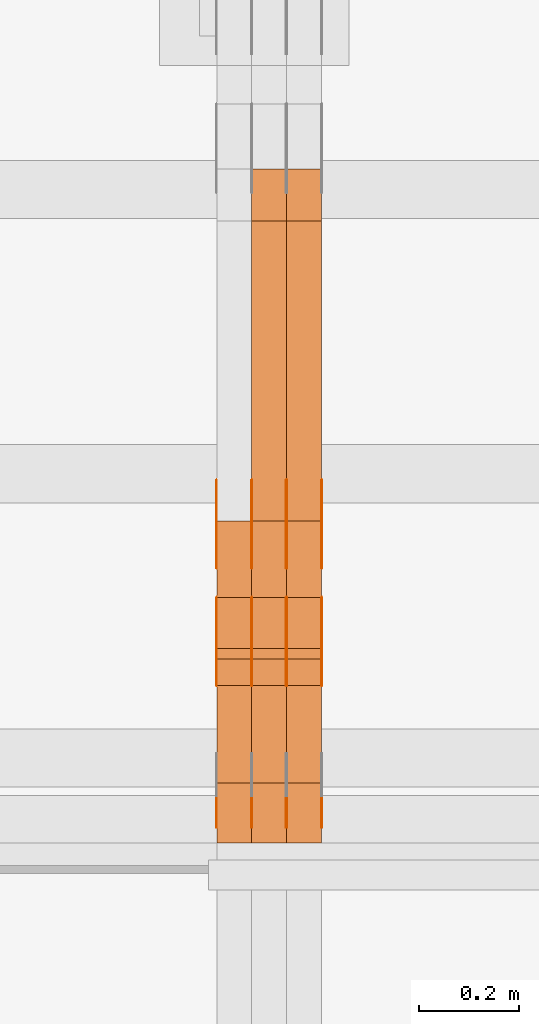
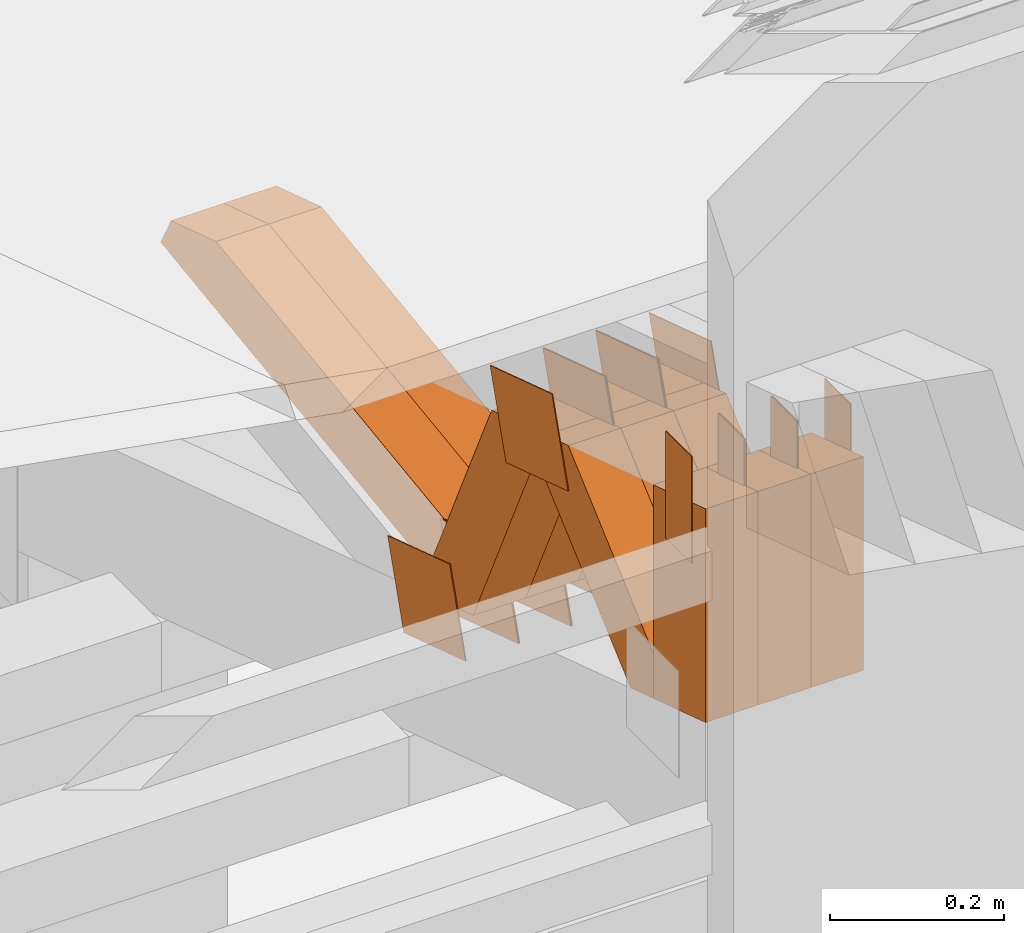
# One storey, part 286 of 385: 29 proxies.
"""IFC2X3 building model written with IfcOpenShell, lengths in millimetres."""

from ifc_helpers import new_model, entity, si_unit, converted_unit, derived_unit, direction, frame, origin, origin_2d_with_axis, place, context, subcontext, project, spatial, polyline, rectangle, outline, extrude, source, transform, mapped, material, type_object, type_shapes, element, save


model = new_model("IFC2X3")

# Units and contexts
model_context = context("Model", 3, precision=0.01, world=origin(), true_north=direction((6.12303176911189e-17, 1.0)))
body_context = subcontext(model_context, "Body", "Model", "MODEL_VIEW")
ifc_project = project(units=[si_unit("LENGTHUNIT", "METRE", prefix="MILLI"), si_unit("AREAUNIT", "SQUARE_METRE"), si_unit("VOLUMEUNIT", "CUBIC_METRE"), converted_unit("PLANEANGLEUNIT", "DEGREE", entity("IfcRatioMeasure", 0.0174532925199433), si_unit("PLANEANGLEUNIT", "RADIAN"), dimensions=[0, 0, 0, 0, 0, 0, 0]), si_unit("MASSUNIT", "GRAM", prefix="KILO"), derived_unit("MASSDENSITYUNIT", [(si_unit("MASSUNIT", "GRAM", prefix="KILO"), 1), (si_unit("LENGTHUNIT", "METRE"), -3)]), si_unit("TIMEUNIT", "SECOND"), si_unit("FREQUENCYUNIT", "HERTZ"), si_unit("THERMODYNAMICTEMPERATUREUNIT", "DEGREE_CELSIUS"), derived_unit("THERMALTRANSMITTANCEUNIT", [(si_unit("MASSUNIT", "GRAM", prefix="KILO"), 1), (si_unit("THERMODYNAMICTEMPERATUREUNIT", "KELVIN"), -1), (si_unit("TIMEUNIT", "SECOND"), -3)]), derived_unit("VOLUMETRICFLOWRATEUNIT", [(si_unit("LENGTHUNIT", "METRE"), 3), (si_unit("TIMEUNIT", "SECOND"), -1)]), si_unit("ELECTRICCURRENTUNIT", "AMPERE"), si_unit("ELECTRICVOLTAGEUNIT", "VOLT"), si_unit("POWERUNIT", "WATT"), si_unit("FORCEUNIT", "NEWTON", prefix="KILO"), si_unit("ILLUMINANCEUNIT", "LUX"), si_unit("LUMINOUSFLUXUNIT", "LUMEN"), si_unit("LUMINOUSINTENSITYUNIT", "CANDELA"), derived_unit("USERDEFINED", [(si_unit("MASSUNIT", "GRAM", prefix="KILO"), -1), (si_unit("LENGTHUNIT", "METRE"), -2), (si_unit("TIMEUNIT", "SECOND"), 3), (si_unit("LUMINOUSFLUXUNIT", "LUMEN"), 1)]), derived_unit("LINEARVELOCITYUNIT", [(si_unit("LENGTHUNIT", "METRE"), 1), (si_unit("TIMEUNIT", "SECOND"), -1)]), si_unit("PRESSUREUNIT", "PASCAL"), derived_unit("USERDEFINED", [(si_unit("LENGTHUNIT", "METRE"), -2), (si_unit("MASSUNIT", "GRAM", prefix="KILO"), 1), (si_unit("TIMEUNIT", "SECOND"), -2)])], contexts=[model_context])

# Site, building, storey
site_placement = place(None, origin())
site = spatial("IfcSite", under=ifc_project, at=site_placement, CompositionType="ELEMENT")
building_placement = place(site_placement, origin())
building = spatial("IfcBuilding", under=site, at=building_placement, CompositionType="ELEMENT")
storey_placement = place(building_placement, origin())
storey = spatial("IfcBuildingStorey", under=building, at=storey_placement, Name="Default", CompositionType="ELEMENT", Elevation=0.0)

# Proxies
ifc_material_1 = material(Name="IfcSurfaceStyle #411628")
building_element_proxy_type_1 = type_object("IfcBuildingElementProxyType", PredefinedType="NOTDEFINED", material=ifc_material_1)
shared_shape_1 = source(origin(), body_context, "Body", "SweptSolid", [
    extrude(outline(polyline([(-74.9998605591118, -59.9999264677601), (74.9998754286171, -59.9999264677601), (74.9998605591118, 59.9999264677602), (-74.9998754286171, 59.9999264677602), (-74.9998605591118, -59.9999264677601)])), frame((74.9998754286171, 60.0000503992849, 0.0), z_axis=(0.0, 0.0, 1.0), x_axis=(-1.0, 0.0, 0.0)), (0.0, 0.0, 1.0), 1.3),
])
type_shapes(building_element_proxy_type_1, [shared_shape_1])
proxy_1_placement = place(building_placement, frame((33386.3, 16352.8320303235, 3323.23212676408), z_axis=(-1.0, 0.0, 0.0), x_axis=(0.0, -0.951056516295124, 0.309016994375039)))
element("IfcBuildingElementProxy", 1, at=proxy_1_placement, inside=storey, type_object=building_element_proxy_type_1, material=ifc_material_1, context=body_context, shape_type="MappedRepresentation", body=[
    mapped(shared_shape_1, transform((0.0, 0.0, 0.0), scale=1.0)),
])
ifc_material_2 = material(Name="IfcSurfaceStyle #411571")
building_element_proxy_type_2 = type_object("IfcBuildingElementProxyType", PredefinedType="NOTDEFINED", material=ifc_material_2)
shared_shape_2 = source(origin(), body_context, "Body", "SweptSolid", [
    extrude(outline(polyline([(-74.9998605591118, -59.9999264677601), (74.9998754286171, -59.9999264677601), (74.9998605591118, 59.9999264677602), (-74.9998754286171, 59.9999264677602), (-74.9998605591118, -59.9999264677601)])), frame((74.9998754286171, 60.0000503992849, 0.0), z_axis=(0.0, 0.0, 1.0), x_axis=(-1.0, 0.0, 0.0)), (0.0, 0.0, 1.0), 1.3),
])
type_shapes(building_element_proxy_type_2, [shared_shape_2])
proxy_2_placement = place(building_placement, frame((33315.0, 16352.8320303235, 3323.23212676408), z_axis=(-1.0, 0.0, 0.0), x_axis=(0.0, -0.951056516295124, 0.309016994375039)))
element("IfcBuildingElementProxy", 2, at=proxy_2_placement, inside=storey, type_object=building_element_proxy_type_2, material=ifc_material_2, context=body_context, shape_type="MappedRepresentation", body=[
    mapped(shared_shape_2, transform((0.0, 0.0, 0.0), scale=1.0)),
])
ifc_material_3 = material(Name="IfcSurfaceStyle #411514")
building_element_proxy_type_3 = type_object("IfcBuildingElementProxyType", PredefinedType="NOTDEFINED", material=ifc_material_3)
shared_shape_3 = source(origin(), body_context, "Body", "SweptSolid", [
    extrude(outline(polyline([(-74.9998605591118, -59.9999264677601), (74.9998754286171, -59.9999264677601), (74.9998605591118, 59.9999264677602), (-74.9998754286171, 59.9999264677602), (-74.9998605591118, -59.9999264677601)])), frame((74.9998754286171, 60.0000503992849, 0.0), z_axis=(0.0, 0.0, 1.0), x_axis=(-1.0, 0.0, 0.0)), (0.0, 0.0, 1.0), 1.3),
])
type_shapes(building_element_proxy_type_3, [shared_shape_3])
proxy_3_placement = place(building_placement, frame((33316.3, 16352.8320303235, 3323.23212676408), z_axis=(-1.0, 0.0, 0.0), x_axis=(0.0, -0.951056516295124, 0.309016994375039)))
element("IfcBuildingElementProxy", 3, at=proxy_3_placement, inside=storey, type_object=building_element_proxy_type_3, material=ifc_material_3, context=body_context, shape_type="MappedRepresentation", body=[
    mapped(shared_shape_3, transform((0.0, 0.0, 0.0), scale=1.0)),
])
ifc_material_4 = material(Name="IfcSurfaceStyle #411457")
building_element_proxy_type_4 = type_object("IfcBuildingElementProxyType", PredefinedType="NOTDEFINED", material=ifc_material_4)
shared_shape_4 = source(origin(), body_context, "Body", "SweptSolid", [
    extrude(outline(polyline([(-74.9998605591118, -59.9999264677601), (74.9998754286171, -59.9999264677601), (74.9998605591118, 59.9999264677602), (-74.9998754286171, 59.9999264677602), (-74.9998605591118, -59.9999264677601)])), frame((74.9998754286171, 60.0000503992849, 0.0), z_axis=(0.0, 0.0, 1.0), x_axis=(-1.0, 0.0, 0.0)), (0.0, 0.0, 1.0), 1.29999999999999),
])
type_shapes(building_element_proxy_type_4, [shared_shape_4])
proxy_4_placement = place(building_placement, frame((33245.0, 16352.8320303235, 3323.23212676408), z_axis=(-1.0, 0.0, 0.0), x_axis=(0.0, -0.951056516295124, 0.309016994375039)))
element("IfcBuildingElementProxy", 4, at=proxy_4_placement, inside=storey, type_object=building_element_proxy_type_4, material=ifc_material_4, context=body_context, shape_type="MappedRepresentation", body=[
    mapped(shared_shape_4, transform((0.0, 0.0, 0.0), scale=1.0)),
])
ifc_material_5 = material(Name="IfcSurfaceStyle #411400")
building_element_proxy_type_5 = type_object("IfcBuildingElementProxyType", PredefinedType="NOTDEFINED", material=ifc_material_5)
shared_shape_5 = source(origin(), body_context, "Body", "SweptSolid", [
    extrude(outline(polyline([(-74.9998605591118, -59.9999264677601), (74.9998754286171, -59.9999264677601), (74.9998605591118, 59.9999264677602), (-74.9998754286171, 59.9999264677602), (-74.9998605591118, -59.9999264677601)])), frame((74.9998754286171, 60.0000503992849, 0.0), z_axis=(0.0, 0.0, 1.0), x_axis=(-1.0, 0.0, 0.0)), (0.0, 0.0, 1.0), 1.29999999999999),
])
type_shapes(building_element_proxy_type_5, [shared_shape_5])
proxy_5_placement = place(building_placement, frame((33246.3, 16352.8320303235, 3323.23212676408), z_axis=(-1.0, 0.0, 0.0), x_axis=(0.0, -0.951056516295124, 0.309016994375039)))
element("IfcBuildingElementProxy", 5, at=proxy_5_placement, inside=storey, type_object=building_element_proxy_type_5, material=ifc_material_5, context=body_context, shape_type="MappedRepresentation", body=[
    mapped(shared_shape_5, transform((0.0, 0.0, 0.0), scale=1.0)),
])
ifc_material_6 = material(Name="IfcSurfaceStyle #411343")
building_element_proxy_type_6 = type_object("IfcBuildingElementProxyType", PredefinedType="NOTDEFINED", material=ifc_material_6)
shared_shape_6 = source(origin(), body_context, "Body", "SweptSolid", [
    extrude(outline(polyline([(-74.9998605591118, -59.9999264677601), (74.9998754286171, -59.9999264677601), (74.9998605591118, 59.9999264677602), (-74.9998754286171, 59.9999264677602), (-74.9998605591118, -59.9999264677601)])), frame((74.9998754286171, 60.0000503992849, 0.0), z_axis=(0.0, 0.0, 1.0), x_axis=(-1.0, 0.0, 0.0)), (0.0, 0.0, 1.0), 1.29999999999999),
])
type_shapes(building_element_proxy_type_6, [shared_shape_6])
proxy_6_placement = place(building_placement, frame((33175.0, 16352.8320303235, 3323.23212676408), z_axis=(-1.0, 0.0, 0.0), x_axis=(0.0, -0.951056516295124, 0.309016994375039)))
element("IfcBuildingElementProxy", 6, at=proxy_6_placement, inside=storey, type_object=building_element_proxy_type_6, material=ifc_material_6, context=body_context, shape_type="MappedRepresentation", body=[
    mapped(shared_shape_6, transform((0.0, 0.0, 0.0), scale=1.0)),
])
ifc_material_7 = material(Name="IfcSurfaceStyle #407182")
building_element_proxy_type_7 = type_object("IfcBuildingElementProxyType", PredefinedType="NOTDEFINED", material=ifc_material_7)
shared_shape_7 = source(origin(), body_context, "Body", "SweptSolid", [
    extrude(outline(polyline([(-75.0003249421702, -60.0000773549573), (75.0003398116874, -60.0000773549573), (75.0003249421711, 60.0000773549573), (-75.0003398116883, 60.0000773549573), (-75.0003249421702, -60.0000773549573)])), frame((75.0003398116874, 60.0000773549573, 0.0), z_axis=(0.0, 0.0, 1.0), x_axis=(-1.0, 0.0, 0.0)), (0.0, 0.0, 1.0), 1.3),
])
type_shapes(building_element_proxy_type_7, [shared_shape_7])
proxy_7_placement = place(building_placement, frame((33386.3, 16117.0849050545, 3705.49074668796), z_axis=(-1.0, 0.0, 0.0), x_axis=(0.0, -0.951056516295154, 0.309016994374948)))
element("IfcBuildingElementProxy", 7, at=proxy_7_placement, inside=storey, type_object=building_element_proxy_type_7, material=ifc_material_7, context=body_context, shape_type="MappedRepresentation", body=[
    mapped(shared_shape_7, transform((0.0, 0.0, 0.0), scale=1.0)),
])
ifc_material_8 = material(Name="IfcSurfaceStyle #407125")
building_element_proxy_type_8 = type_object("IfcBuildingElementProxyType", PredefinedType="NOTDEFINED", material=ifc_material_8)
shared_shape_8 = source(origin(), body_context, "Body", "SweptSolid", [
    extrude(outline(polyline([(-75.0003249421702, -60.0000773549573), (75.0003398116874, -60.0000773549573), (75.0003249421711, 60.0000773549573), (-75.0003398116883, 60.0000773549573), (-75.0003249421702, -60.0000773549573)])), frame((75.0003398116874, 60.0000773549573, 0.0), z_axis=(0.0, 0.0, 1.0), x_axis=(-1.0, 0.0, 0.0)), (0.0, 0.0, 1.0), 1.3),
])
type_shapes(building_element_proxy_type_8, [shared_shape_8])
proxy_8_placement = place(building_placement, frame((33315.0, 16117.0849050545, 3705.49074668796), z_axis=(-1.0, 0.0, 0.0), x_axis=(0.0, -0.951056516295154, 0.309016994374948)))
element("IfcBuildingElementProxy", 8, at=proxy_8_placement, inside=storey, type_object=building_element_proxy_type_8, material=ifc_material_8, context=body_context, shape_type="MappedRepresentation", body=[
    mapped(shared_shape_8, transform((0.0, 0.0, 0.0), scale=1.0)),
])
ifc_material_9 = material(Name="IfcSurfaceStyle #407068")
building_element_proxy_type_9 = type_object("IfcBuildingElementProxyType", PredefinedType="NOTDEFINED", material=ifc_material_9)
shared_shape_9 = source(origin(), body_context, "Body", "SweptSolid", [
    extrude(outline(polyline([(-75.0003249421702, -60.0000773549573), (75.0003398116874, -60.0000773549573), (75.0003249421711, 60.0000773549573), (-75.0003398116883, 60.0000773549573), (-75.0003249421702, -60.0000773549573)])), frame((75.0003398116874, 60.0000773549573, 0.0), z_axis=(0.0, 0.0, 1.0), x_axis=(-1.0, 0.0, 0.0)), (0.0, 0.0, 1.0), 1.3),
])
type_shapes(building_element_proxy_type_9, [shared_shape_9])
proxy_9_placement = place(building_placement, frame((33316.3, 16117.0849050545, 3705.49074668796), z_axis=(-1.0, 0.0, 0.0), x_axis=(0.0, -0.951056516295154, 0.309016994374948)))
element("IfcBuildingElementProxy", 9, at=proxy_9_placement, inside=storey, type_object=building_element_proxy_type_9, material=ifc_material_9, context=body_context, shape_type="MappedRepresentation", body=[
    mapped(shared_shape_9, transform((0.0, 0.0, 0.0), scale=1.0)),
])
ifc_material_10 = material(Name="IfcSurfaceStyle #407011")
building_element_proxy_type_10 = type_object("IfcBuildingElementProxyType", PredefinedType="NOTDEFINED", material=ifc_material_10)
shared_shape_10 = source(origin(), body_context, "Body", "SweptSolid", [
    extrude(outline(polyline([(-75.0003249421702, -60.0000773549573), (75.0003398116874, -60.0000773549573), (75.0003249421711, 60.0000773549573), (-75.0003398116883, 60.0000773549573), (-75.0003249421702, -60.0000773549573)])), frame((75.0003398116874, 60.0000773549573, 0.0), z_axis=(0.0, 0.0, 1.0), x_axis=(-1.0, 0.0, 0.0)), (0.0, 0.0, 1.0), 1.29999999999999),
])
type_shapes(building_element_proxy_type_10, [shared_shape_10])
proxy_10_placement = place(building_placement, frame((33245.0, 16117.0849050545, 3705.49074668796), z_axis=(-1.0, 0.0, 0.0), x_axis=(0.0, -0.951056516295154, 0.309016994374948)))
element("IfcBuildingElementProxy", 10, at=proxy_10_placement, inside=storey, type_object=building_element_proxy_type_10, material=ifc_material_10, context=body_context, shape_type="MappedRepresentation", body=[
    mapped(shared_shape_10, transform((0.0, 0.0, 0.0), scale=1.0)),
])
ifc_material_11 = material(Name="IfcSurfaceStyle #406954")
building_element_proxy_type_11 = type_object("IfcBuildingElementProxyType", PredefinedType="NOTDEFINED", material=ifc_material_11)
shared_shape_11 = source(origin(), body_context, "Body", "SweptSolid", [
    extrude(outline(polyline([(-75.0003249421702, -60.0000773549573), (75.0003398116874, -60.0000773549573), (75.0003249421711, 60.0000773549573), (-75.0003398116883, 60.0000773549573), (-75.0003249421702, -60.0000773549573)])), frame((75.0003398116874, 60.0000773549573, 0.0), z_axis=(0.0, 0.0, 1.0), x_axis=(-1.0, 0.0, 0.0)), (0.0, 0.0, 1.0), 1.29999999999999),
])
type_shapes(building_element_proxy_type_11, [shared_shape_11])
proxy_11_placement = place(building_placement, frame((33246.3, 16117.0849050545, 3705.49074668796), z_axis=(-1.0, 0.0, 0.0), x_axis=(0.0, -0.951056516295154, 0.309016994374948)))
element("IfcBuildingElementProxy", 11, at=proxy_11_placement, inside=storey, type_object=building_element_proxy_type_11, material=ifc_material_11, context=body_context, shape_type="MappedRepresentation", body=[
    mapped(shared_shape_11, transform((0.0, 0.0, 0.0), scale=1.0)),
])
ifc_material_12 = material(Name="IfcSurfaceStyle #406897")
building_element_proxy_type_12 = type_object("IfcBuildingElementProxyType", PredefinedType="NOTDEFINED", material=ifc_material_12)
shared_shape_12 = source(origin(), body_context, "Body", "SweptSolid", [
    extrude(outline(polyline([(-75.0003249421702, -60.0000773549573), (75.0003398116874, -60.0000773549573), (75.0003249421711, 60.0000773549573), (-75.0003398116883, 60.0000773549573), (-75.0003249421702, -60.0000773549573)])), frame((75.0003398116874, 60.0000773549573, 0.0), z_axis=(0.0, 0.0, 1.0), x_axis=(-1.0, 0.0, 0.0)), (0.0, 0.0, 1.0), 1.29999999999999),
])
type_shapes(building_element_proxy_type_12, [shared_shape_12])
proxy_12_placement = place(building_placement, frame((33175.0, 16117.0849050545, 3705.49074668796), z_axis=(-1.0, 0.0, 0.0), x_axis=(0.0, -0.951056516295154, 0.309016994374948)))
element("IfcBuildingElementProxy", 12, at=proxy_12_placement, inside=storey, type_object=building_element_proxy_type_12, material=ifc_material_12, context=body_context, shape_type="MappedRepresentation", body=[
    mapped(shared_shape_12, transform((0.0, 0.0, 0.0), scale=1.0)),
])
ifc_material_13 = material(Name="IfcSurfaceStyle #406498")
building_element_proxy_type_13 = type_object("IfcBuildingElementProxyType", PredefinedType="NOTDEFINED", material=ifc_material_13)
shared_shape_13 = source(origin(), body_context, "Body", "SweptSolid", [
    extrude(rectangle(XDim=150.0, YDim=60.0, at=origin_2d_with_axis()), frame((75.0000705696311, 30.0, 0.0), z_axis=(0.0, 0.0, 1.0), x_axis=(-1.0, 0.0, 0.0)), (0.0, 0.0, 1.0), 1.3),
])
type_shapes(building_element_proxy_type_13, [shared_shape_13])
proxy_13_placement = place(building_placement, frame((33386.3, 15750.0, 3972.59919166338), z_axis=(-1.0, 0.0, 0.0), x_axis=(0.0, 0.0, -1.0)))
element("IfcBuildingElementProxy", 13, at=proxy_13_placement, inside=storey, type_object=building_element_proxy_type_13, material=ifc_material_13, context=body_context, shape_type="MappedRepresentation", body=[
    mapped(shared_shape_13, transform((0.0, 0.0, 0.0), scale=1.0)),
])
ifc_material_14 = material(Name="IfcSurfaceStyle #406441")
building_element_proxy_type_14 = type_object("IfcBuildingElementProxyType", PredefinedType="NOTDEFINED", material=ifc_material_14)
shared_shape_14 = source(origin(), body_context, "Body", "SweptSolid", [
    extrude(rectangle(XDim=150.0, YDim=60.0, at=origin_2d_with_axis()), frame((75.0000705696311, 30.0, 0.0), z_axis=(0.0, 0.0, 1.0), x_axis=(-1.0, 0.0, 0.0)), (0.0, 0.0, 1.0), 1.3),
])
type_shapes(building_element_proxy_type_14, [shared_shape_14])
proxy_14_placement = place(building_placement, frame((33315.0, 15750.0, 3972.59919166338), z_axis=(-1.0, 0.0, 0.0), x_axis=(0.0, 0.0, -1.0)))
element("IfcBuildingElementProxy", 14, at=proxy_14_placement, inside=storey, type_object=building_element_proxy_type_14, material=ifc_material_14, context=body_context, shape_type="MappedRepresentation", body=[
    mapped(shared_shape_14, transform((0.0, 0.0, 0.0), scale=1.0)),
])
ifc_material_15 = material(Name="IfcSurfaceStyle #406384")
building_element_proxy_type_15 = type_object("IfcBuildingElementProxyType", PredefinedType="NOTDEFINED", material=ifc_material_15)
shared_shape_15 = source(origin(), body_context, "Body", "SweptSolid", [
    extrude(rectangle(XDim=150.0, YDim=60.0, at=origin_2d_with_axis()), frame((75.0000705696311, 30.0, 0.0), z_axis=(0.0, 0.0, 1.0), x_axis=(-1.0, 0.0, 0.0)), (0.0, 0.0, 1.0), 1.3),
])
type_shapes(building_element_proxy_type_15, [shared_shape_15])
proxy_15_placement = place(building_placement, frame((33316.3, 15750.0, 3972.59919166338), z_axis=(-1.0, 0.0, 0.0), x_axis=(0.0, 0.0, -1.0)))
element("IfcBuildingElementProxy", 15, at=proxy_15_placement, inside=storey, type_object=building_element_proxy_type_15, material=ifc_material_15, context=body_context, shape_type="MappedRepresentation", body=[
    mapped(shared_shape_15, transform((0.0, 0.0, 0.0), scale=1.0)),
])
ifc_material_16 = material(Name="IfcSurfaceStyle #406327")
building_element_proxy_type_16 = type_object("IfcBuildingElementProxyType", PredefinedType="NOTDEFINED", material=ifc_material_16)
shared_shape_16 = source(origin(), body_context, "Body", "SweptSolid", [
    extrude(rectangle(XDim=150.0, YDim=60.0, at=origin_2d_with_axis()), frame((75.0000705696311, 30.0, 0.0), z_axis=(0.0, 0.0, 1.0), x_axis=(-1.0, 0.0, 0.0)), (0.0, 0.0, 1.0), 1.29999999999999),
])
type_shapes(building_element_proxy_type_16, [shared_shape_16])
proxy_16_placement = place(building_placement, frame((33245.0, 15750.0, 3972.59919166338), z_axis=(-1.0, 0.0, 0.0), x_axis=(0.0, 0.0, -1.0)))
element("IfcBuildingElementProxy", 16, at=proxy_16_placement, inside=storey, type_object=building_element_proxy_type_16, material=ifc_material_16, context=body_context, shape_type="MappedRepresentation", body=[
    mapped(shared_shape_16, transform((0.0, 0.0, 0.0), scale=1.0)),
])
ifc_material_17 = material(Name="IfcSurfaceStyle #406270")
building_element_proxy_type_17 = type_object("IfcBuildingElementProxyType", PredefinedType="NOTDEFINED", material=ifc_material_17)
shared_shape_17 = source(origin(), body_context, "Body", "SweptSolid", [
    extrude(rectangle(XDim=150.0, YDim=60.0, at=origin_2d_with_axis()), frame((75.0000705696311, 30.0, 0.0), z_axis=(0.0, 0.0, 1.0), x_axis=(-1.0, 0.0, 0.0)), (0.0, 0.0, 1.0), 1.29999999999999),
])
type_shapes(building_element_proxy_type_17, [shared_shape_17])
proxy_17_placement = place(building_placement, frame((33246.3, 15750.0, 3972.59919166338), z_axis=(-1.0, 0.0, 0.0), x_axis=(0.0, 0.0, -1.0)))
element("IfcBuildingElementProxy", 17, at=proxy_17_placement, inside=storey, type_object=building_element_proxy_type_17, material=ifc_material_17, context=body_context, shape_type="MappedRepresentation", body=[
    mapped(shared_shape_17, transform((0.0, 0.0, 0.0), scale=1.0)),
])
ifc_material_18 = material(Name="IfcSurfaceStyle #406213")
building_element_proxy_type_18 = type_object("IfcBuildingElementProxyType", PredefinedType="NOTDEFINED", material=ifc_material_18)
shared_shape_18 = source(origin(), body_context, "Body", "SweptSolid", [
    extrude(rectangle(XDim=150.0, YDim=60.0, at=origin_2d_with_axis()), frame((75.0000705696311, 30.0, 0.0), z_axis=(0.0, 0.0, 1.0), x_axis=(-1.0, 0.0, 0.0)), (0.0, 0.0, 1.0), 1.29999999999999),
])
type_shapes(building_element_proxy_type_18, [shared_shape_18])
proxy_18_placement = place(building_placement, frame((33175.0, 15750.0, 3972.59919166338), z_axis=(-1.0, 0.0, 0.0), x_axis=(0.0, 0.0, -1.0)))
element("IfcBuildingElementProxy", 18, at=proxy_18_placement, inside=storey, type_object=building_element_proxy_type_18, material=ifc_material_18, context=body_context, shape_type="MappedRepresentation", body=[
    mapped(shared_shape_18, transform((0.0, 0.0, 0.0), scale=1.0)),
])
ifc_material_19 = material(Name="IfcSurfaceStyle #397129")
building_element_proxy_type_19 = type_object("IfcBuildingElementProxyType", Name="T1-W50 397127", PredefinedType="NOTDEFINED", material=ifc_material_19)
shared_shape_19 = source(origin(), body_context, "Body", "SweptSolid", [
    extrude(outline(polyline([(-128.56619634284, -47.4999385885712), (133.151257249084, -47.4999385885712), (161.172800006526, -0.000129729183733609), (147.291467726413, 47.500068317755), (-142.513973767368, 47.500068317755), (-170.535354871815, -0.000129729183754689), (-128.56619634284, -47.4999385885712)])), frame((161.17310141218, 47.5001898716564, 0.0), z_axis=(0.0, 0.0, 1.0), x_axis=(-1.0, 0.0, 0.0)), (0.0, 0.0, 1.0), 70.0),
])
type_shapes(building_element_proxy_type_19, [shared_shape_19])
proxy_19_placement = place(building_placement, frame((33385.0, 16060.0297689714, 3761.73994820667), z_axis=(-1.0, 0.0, 0.0), x_axis=(0.0, -0.749388407538668, -0.662130662820156)))
element("IfcBuildingElementProxy", 19, at=proxy_19_placement, inside=storey, type_object=building_element_proxy_type_19, material=ifc_material_19, Name="T1-W50", context=body_context, shape_type="MappedRepresentation", body=[
    mapped(shared_shape_19, transform((0.0, 0.0, 0.0), scale=1.0)),
])
ifc_material_20 = material(Name="IfcSurfaceStyle #397054")
building_element_proxy_type_20 = type_object("IfcBuildingElementProxyType", Name="T1-W50 397052", PredefinedType="NOTDEFINED", material=ifc_material_20)
shared_shape_20 = source(origin(), body_context, "Body", "SweptSolid", [
    extrude(outline(polyline([(-128.56619634284, -47.4999385885712), (133.151257249084, -47.4999385885712), (161.172800006526, -0.000129729183733609), (147.291467726413, 47.500068317755), (-142.513973767368, 47.500068317755), (-170.535354871815, -0.000129729183754689), (-128.56619634284, -47.4999385885712)])), frame((161.17310141218, 47.5001898716564, 0.0), z_axis=(0.0, 0.0, 1.0), x_axis=(-1.0, 0.0, 0.0)), (0.0, 0.0, 1.0), 70.0),
])
type_shapes(building_element_proxy_type_20, [shared_shape_20])
proxy_20_placement = place(building_placement, frame((33315.0, 16060.0297689714, 3761.73994820667), z_axis=(-1.0, 0.0, 0.0), x_axis=(0.0, -0.749388407538668, -0.662130662820156)))
element("IfcBuildingElementProxy", 20, at=proxy_20_placement, inside=storey, type_object=building_element_proxy_type_20, material=ifc_material_20, Name="T1-W50", context=body_context, shape_type="MappedRepresentation", body=[
    mapped(shared_shape_20, transform((0.0, 0.0, 0.0), scale=1.0)),
])
ifc_material_21 = material(Name="IfcSurfaceStyle #396979")
building_element_proxy_type_21 = type_object("IfcBuildingElementProxyType", Name="T1-W50 396977", PredefinedType="NOTDEFINED", material=ifc_material_21)
shared_shape_21 = source(origin(), body_context, "Body", "SweptSolid", [
    extrude(outline(polyline([(-128.56619634284, -47.4999385885712), (133.151257249084, -47.4999385885712), (161.172800006526, -0.000129729183733609), (147.291467726413, 47.500068317755), (-142.513973767368, 47.500068317755), (-170.535354871815, -0.000129729183754689), (-128.56619634284, -47.4999385885712)])), frame((161.17310141218, 47.5001898716564, 0.0), z_axis=(0.0, 0.0, 1.0), x_axis=(-1.0, 0.0, 0.0)), (0.0, 0.0, 1.0), 70.0),
])
type_shapes(building_element_proxy_type_21, [shared_shape_21])
proxy_21_placement = place(building_placement, frame((33245.0, 16060.0297689714, 3761.73994820667), z_axis=(-1.0, 0.0, 0.0), x_axis=(0.0, -0.749388407538668, -0.662130662820156)))
element("IfcBuildingElementProxy", 21, at=proxy_21_placement, inside=storey, type_object=building_element_proxy_type_21, material=ifc_material_21, Name="T1-W50", context=body_context, shape_type="MappedRepresentation", body=[
    mapped(shared_shape_21, transform((0.0, 0.0, 0.0), scale=1.0)),
])
ifc_material_22 = material(Name="IfcSurfaceStyle #396733")
building_element_proxy_type_22 = type_object("IfcBuildingElementProxyType", Name="T1-W2 396731", PredefinedType="NOTDEFINED", material=ifc_material_22)
shared_shape_22 = source(origin(), body_context, "Body", "SweptSolid", [
    extrude(outline(polyline([(-130.705993652344, -60.0), (169.696350097656, -60.0), (130.706115722656, 60.0), (-169.696472167969, 60.0), (-130.705993652344, -60.0)])), frame((169.696429629256, 60.0, 0.0), z_axis=(0.0, 0.0, 1.0), x_axis=(-1.0, 0.0, 0.0)), (0.0, 0.0, 1.0), 70.0),
])
type_shapes(building_element_proxy_type_22, [shared_shape_22])
proxy_22_placement = place(building_placement, frame((33385.0, 15660.0, 3577.70158062465), z_axis=(-1.0, 0.0, 0.0), x_axis=(0.0, 0.0, 1.0)))
element("IfcBuildingElementProxy", 22, at=proxy_22_placement, inside=storey, type_object=building_element_proxy_type_22, material=ifc_material_22, Name="T1-W2", context=body_context, shape_type="MappedRepresentation", body=[
    mapped(shared_shape_22, transform((0.0, 0.0, 0.0), scale=1.0)),
])
ifc_material_23 = material(Name="IfcSurfaceStyle #396676")
building_element_proxy_type_23 = type_object("IfcBuildingElementProxyType", Name="T1-W2 396674", PredefinedType="NOTDEFINED", material=ifc_material_23)
shared_shape_23 = source(origin(), body_context, "Body", "SweptSolid", [
    extrude(outline(polyline([(-130.705993652344, -60.0), (169.696350097656, -60.0), (130.706115722656, 60.0), (-169.696472167969, 60.0), (-130.705993652344, -60.0)])), frame((169.696429629256, 60.0, 0.0), z_axis=(0.0, 0.0, 1.0), x_axis=(-1.0, 0.0, 0.0)), (0.0, 0.0, 1.0), 70.0),
])
type_shapes(building_element_proxy_type_23, [shared_shape_23])
proxy_23_placement = place(building_placement, frame((33315.0, 15660.0, 3577.70158062465), z_axis=(-1.0, 0.0, 0.0), x_axis=(0.0, 0.0, 1.0)))
element("IfcBuildingElementProxy", 23, at=proxy_23_placement, inside=storey, type_object=building_element_proxy_type_23, material=ifc_material_23, Name="T1-W2", context=body_context, shape_type="MappedRepresentation", body=[
    mapped(shared_shape_23, transform((0.0, 0.0, 0.0), scale=1.0)),
])
ifc_material_24 = material(Name="IfcSurfaceStyle #396619")
building_element_proxy_type_24 = type_object("IfcBuildingElementProxyType", Name="T1-W2 396617", PredefinedType="NOTDEFINED", material=ifc_material_24)
shared_shape_24 = source(origin(), body_context, "Body", "SweptSolid", [
    extrude(outline(polyline([(-130.705993652344, -60.0), (169.696350097656, -60.0), (130.706115722656, 60.0), (-169.696472167969, 60.0), (-130.705993652344, -60.0)])), frame((169.696429629256, 60.0, 0.0), z_axis=(0.0, 0.0, 1.0), x_axis=(-1.0, 0.0, 0.0)), (0.0, 0.0, 1.0), 70.0),
])
type_shapes(building_element_proxy_type_24, [shared_shape_24])
proxy_24_placement = place(building_placement, frame((33245.0, 15660.0, 3577.70158062465), z_axis=(-1.0, 0.0, 0.0), x_axis=(0.0, 0.0, 1.0)))
element("IfcBuildingElementProxy", 24, at=proxy_24_placement, inside=storey, type_object=building_element_proxy_type_24, material=ifc_material_24, Name="T1-W2", context=body_context, shape_type="MappedRepresentation", body=[
    mapped(shared_shape_24, transform((0.0, 0.0, 0.0), scale=1.0)),
])
ifc_material_25 = material(Name="IfcSurfaceStyle #396562")
building_element_proxy_type_25 = type_object("IfcBuildingElementProxyType", Name="T1-W44 396560", PredefinedType="NOTDEFINED", material=ifc_material_25)
shared_shape_25 = source(origin(), body_context, "Body", "SweptSolid", [
    extrude(outline(polyline([(-184.551057772692, -47.4997984945814), (177.527112951531, -47.4997984945814), (162.630077773546, -0.000452497529500495), (118.068221667048, 47.5000247433462), (-273.674354619433, 47.5000247433462), (-184.551057772692, -47.4997984945814)])), frame((177.527112951531, 47.5002721629815, 0.0), z_axis=(0.0, 0.0, 1.0), x_axis=(-1.0, 0.0, 0.0)), (0.0, 0.0, 1.0), 70.0),
])
type_shapes(building_element_proxy_type_25, [shared_shape_25])
proxy_25_placement = place(building_placement, frame((33385.0, 16220.4899216004, 3388.98238154171), z_axis=(-1.0, 0.0, 0.0), x_axis=(0.0, -0.425335045192995, 0.905035965766374)))
element("IfcBuildingElementProxy", 25, at=proxy_25_placement, inside=storey, type_object=building_element_proxy_type_25, material=ifc_material_25, Name="T1-W44", context=body_context, shape_type="MappedRepresentation", body=[
    mapped(shared_shape_25, transform((0.0, 0.0, 0.0), scale=1.0)),
])
ifc_material_26 = material(Name="IfcSurfaceStyle #396496")
building_element_proxy_type_26 = type_object("IfcBuildingElementProxyType", Name="T1-W44 396494", PredefinedType="NOTDEFINED", material=ifc_material_26)
shared_shape_26 = source(origin(), body_context, "Body", "SweptSolid", [
    extrude(outline(polyline([(-184.551057772692, -47.4997984945814), (177.527112951531, -47.4997984945814), (162.630077773546, -0.000452497529500495), (118.068221667048, 47.5000247433462), (-273.674354619433, 47.5000247433462), (-184.551057772692, -47.4997984945814)])), frame((177.527112951531, 47.5002721629815, 0.0), z_axis=(0.0, 0.0, 1.0), x_axis=(-1.0, 0.0, 0.0)), (0.0, 0.0, 1.0), 70.0),
])
type_shapes(building_element_proxy_type_26, [shared_shape_26])
proxy_26_placement = place(building_placement, frame((33315.0, 16220.4899216004, 3388.98238154171), z_axis=(-1.0, 0.0, 0.0), x_axis=(0.0, -0.425335045192995, 0.905035965766374)))
element("IfcBuildingElementProxy", 26, at=proxy_26_placement, inside=storey, type_object=building_element_proxy_type_26, material=ifc_material_26, Name="T1-W44", context=body_context, shape_type="MappedRepresentation", body=[
    mapped(shared_shape_26, transform((0.0, 0.0, 0.0), scale=1.0)),
])
ifc_material_27 = material(Name="IfcSurfaceStyle #396430")
building_element_proxy_type_27 = type_object("IfcBuildingElementProxyType", Name="T1-W44 396428", PredefinedType="NOTDEFINED", material=ifc_material_27)
shared_shape_27 = source(origin(), body_context, "Body", "SweptSolid", [
    extrude(outline(polyline([(-184.551057772692, -47.4997984945814), (177.527112951531, -47.4997984945814), (162.630077773546, -0.000452497529500495), (118.068221667048, 47.5000247433462), (-273.674354619433, 47.5000247433462), (-184.551057772692, -47.4997984945814)])), frame((177.527112951531, 47.5002721629815, 0.0), z_axis=(0.0, 0.0, 1.0), x_axis=(-1.0, 0.0, 0.0)), (0.0, 0.0, 1.0), 70.0),
])
type_shapes(building_element_proxy_type_27, [shared_shape_27])
proxy_27_placement = place(building_placement, frame((33245.0, 16220.4899216004, 3388.98238154171), z_axis=(-1.0, 0.0, 0.0), x_axis=(0.0, -0.425335045192995, 0.905035965766374)))
element("IfcBuildingElementProxy", 27, at=proxy_27_placement, inside=storey, type_object=building_element_proxy_type_27, material=ifc_material_27, Name="T1-W44", context=body_context, shape_type="MappedRepresentation", body=[
    mapped(shared_shape_27, transform((0.0, 0.0, 0.0), scale=1.0)),
])
ifc_material_28 = material(Name="IfcSurfaceStyle #396166")
building_element_proxy_type_28 = type_object("IfcBuildingElementProxyType", Name="T1-W8 396164", PredefinedType="NOTDEFINED", material=ifc_material_28)
shared_shape_28 = source(origin(), body_context, "Body", "SweptSolid", [
    extrude(outline(polyline([(-476.725263324644, -47.5001051695965), (180.672765845439, -47.5001051695965), (279.11020091716, -1.03605560390907e-06), (296.793624402619, 47.5001056876243), (-279.851327840575, 47.5001056876243), (-476.725263324644, -47.5001051695965)])), frame((296.793624402619, 47.5001056876243, 0.0), z_axis=(0.0, 0.0, 1.0), x_axis=(-1.0, 0.0, 0.0)), (0.0, 0.0, 1.0), 70.0),
])
type_shapes(building_element_proxy_type_28, [shared_shape_28])
proxy_28_placement = place(building_placement, frame((33385.0, 17036.40625, 3432.97192382813), z_axis=(-1.0, 0.0, 0.0), x_axis=(0.0, -0.990844046556832, -0.135011389900564)))
element("IfcBuildingElementProxy", 28, at=proxy_28_placement, inside=storey, type_object=building_element_proxy_type_28, material=ifc_material_28, Name="T1-W8", context=body_context, shape_type="MappedRepresentation", body=[
    mapped(shared_shape_28, transform((0.0, 0.0, 0.0), scale=1.0)),
])
ifc_material_29 = material(Name="IfcSurfaceStyle #396100")
building_element_proxy_type_29 = type_object("IfcBuildingElementProxyType", Name="T1-W8 396098", PredefinedType="NOTDEFINED", material=ifc_material_29)
shared_shape_29 = source(origin(), body_context, "Body", "SweptSolid", [
    extrude(outline(polyline([(-476.725263324644, -47.5001051695965), (180.672765845439, -47.5001051695965), (279.11020091716, -1.03605560390907e-06), (296.793624402619, 47.5001056876243), (-279.851327840575, 47.5001056876243), (-476.725263324644, -47.5001051695965)])), frame((296.793624402619, 47.5001056876243, 0.0), z_axis=(0.0, 0.0, 1.0), x_axis=(-1.0, 0.0, 0.0)), (0.0, 0.0, 1.0), 70.0),
])
type_shapes(building_element_proxy_type_29, [shared_shape_29])
proxy_29_placement = place(building_placement, frame((33315.0, 17036.40625, 3432.97192382813), z_axis=(-1.0, 0.0, 0.0), x_axis=(0.0, -0.990844046556832, -0.135011389900564)))
element("IfcBuildingElementProxy", 29, at=proxy_29_placement, inside=storey, type_object=building_element_proxy_type_29, material=ifc_material_29, Name="T1-W8", context=body_context, shape_type="MappedRepresentation", body=[
    mapped(shared_shape_29, transform((0.0, 0.0, 0.0), scale=1.0)),
])

save(model, "model.ifc")
